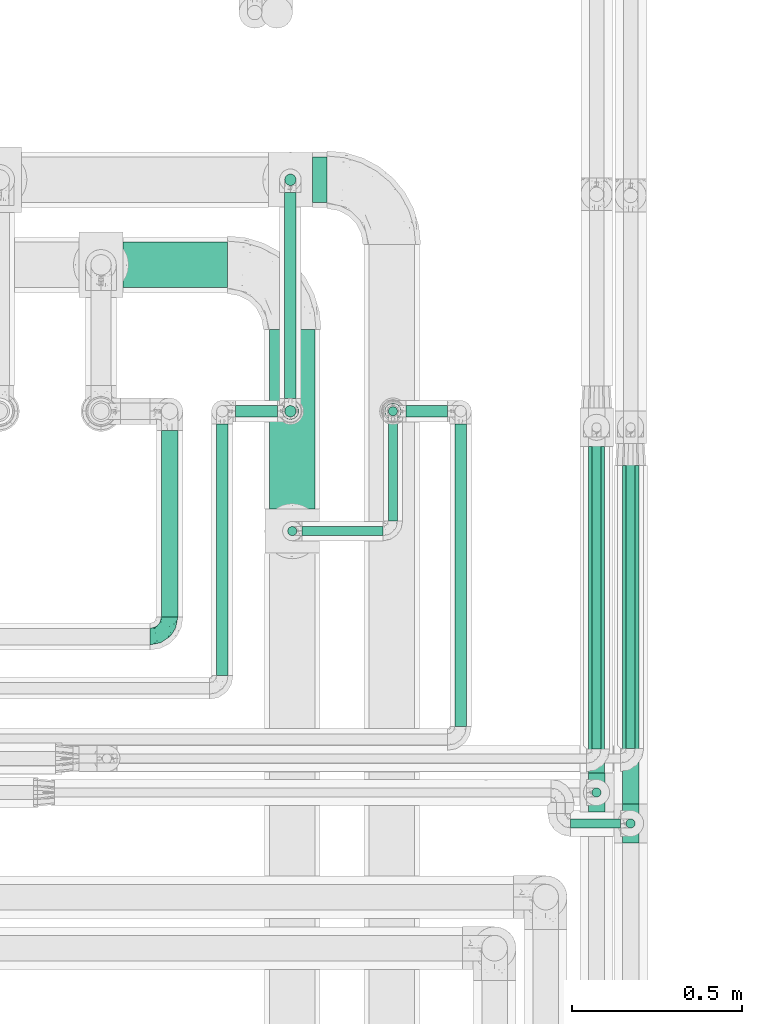
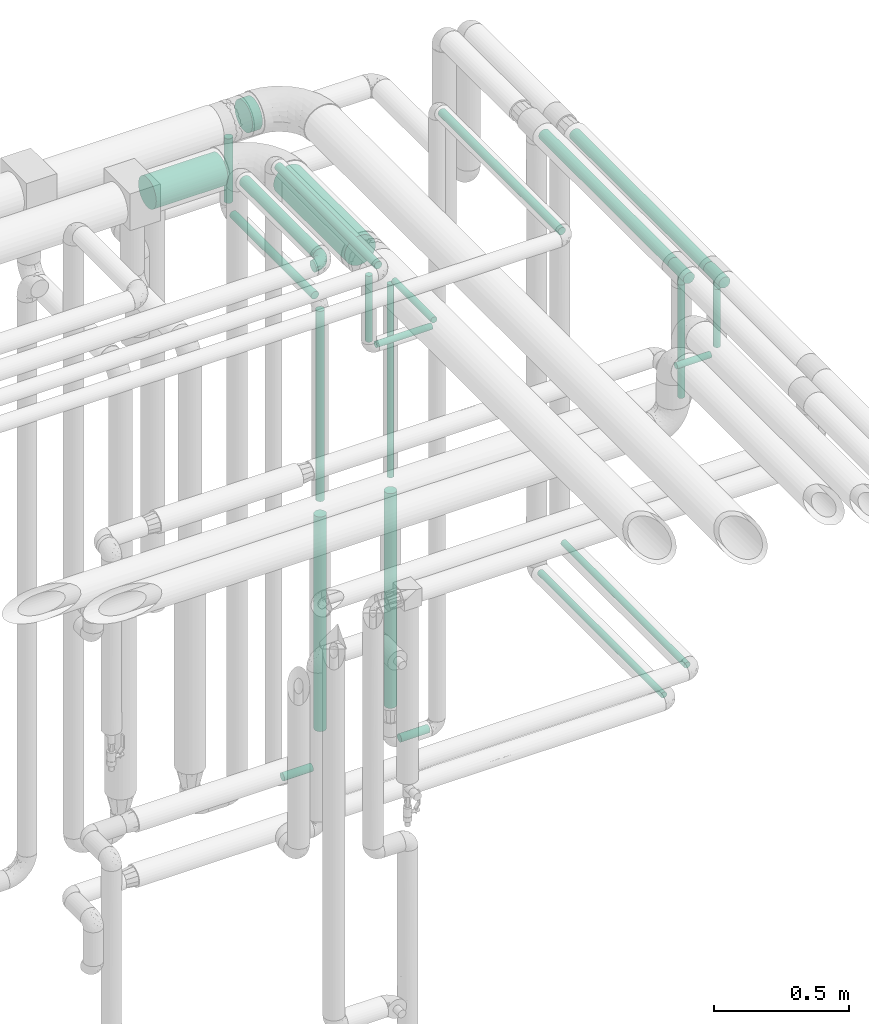
# One storey, part 725 of 827: 24 flow segments, 3 flow fittings.
"""IFC2X3 building model written with IfcOpenShell, lengths in millimetres."""

from ifc_helpers import new_model, entity, si_unit, converted_unit, derived_unit, direction, frame, origin, origin_2d_with_axis, place, context, subcontext, project, spatial, circle, extrude, faceted_brep, source, transform, mapped, material, type_object, type_shapes, element, save


model = new_model("IFC2X3")

# Units and contexts
model_context = context("Model", 3, precision=0.01, world=origin(), true_north=direction((6.12303176911189e-17, 1.0)))
body_context = subcontext(model_context, "Body", "Model", "MODEL_VIEW")
ifc_project = project(units=[si_unit("LENGTHUNIT", "METRE", prefix="MILLI"), si_unit("AREAUNIT", "SQUARE_METRE"), si_unit("VOLUMEUNIT", "CUBIC_METRE"), converted_unit("PLANEANGLEUNIT", "DEGREE", entity("IfcRatioMeasure", 0.0174532925199433), si_unit("PLANEANGLEUNIT", "RADIAN"), dimensions=[0, 0, 0, 0, 0, 0, 0]), si_unit("MASSUNIT", "GRAM", prefix="KILO"), derived_unit("MASSDENSITYUNIT", [(si_unit("MASSUNIT", "GRAM", prefix="KILO"), 1), (si_unit("LENGTHUNIT", "METRE"), -3)]), derived_unit("MOMENTOFINERTIAUNIT", [(si_unit("LENGTHUNIT", "METRE"), 4)]), si_unit("TIMEUNIT", "SECOND"), si_unit("FREQUENCYUNIT", "HERTZ"), si_unit("THERMODYNAMICTEMPERATUREUNIT", "DEGREE_CELSIUS"), derived_unit("THERMALTRANSMITTANCEUNIT", [(si_unit("MASSUNIT", "GRAM", prefix="KILO"), 1), (si_unit("THERMODYNAMICTEMPERATUREUNIT", "KELVIN"), -1), (si_unit("TIMEUNIT", "SECOND"), -3)]), derived_unit("VOLUMETRICFLOWRATEUNIT", [(si_unit("LENGTHUNIT", "METRE"), 3), (si_unit("TIMEUNIT", "SECOND"), -1)]), derived_unit("MASSFLOWRATEUNIT", [(si_unit("MASSUNIT", "GRAM", prefix="KILO"), 1), (si_unit("TIMEUNIT", "SECOND"), -1)]), derived_unit("ROTATIONALFREQUENCYUNIT", [(si_unit("TIMEUNIT", "SECOND"), -1)]), si_unit("ELECTRICCURRENTUNIT", "AMPERE"), si_unit("ELECTRICVOLTAGEUNIT", "VOLT"), si_unit("POWERUNIT", "WATT"), si_unit("FORCEUNIT", "NEWTON", prefix="KILO"), si_unit("ILLUMINANCEUNIT", "LUX"), si_unit("LUMINOUSFLUXUNIT", "LUMEN"), si_unit("LUMINOUSINTENSITYUNIT", "CANDELA"), derived_unit("USERDEFINED", [(si_unit("MASSUNIT", "GRAM", prefix="KILO"), -1), (si_unit("LENGTHUNIT", "METRE"), -2), (si_unit("TIMEUNIT", "SECOND"), 3), (si_unit("LUMINOUSFLUXUNIT", "LUMEN"), 1)]), derived_unit("LINEARVELOCITYUNIT", [(si_unit("LENGTHUNIT", "METRE"), 1), (si_unit("TIMEUNIT", "SECOND"), -1)]), si_unit("PRESSUREUNIT", "PASCAL"), derived_unit("USERDEFINED", [(si_unit("LENGTHUNIT", "METRE"), -2), (si_unit("MASSUNIT", "GRAM", prefix="KILO"), 1), (si_unit("TIMEUNIT", "SECOND"), -2)]), derived_unit("LINEARFORCEUNIT", [(si_unit("MASSUNIT", "GRAM", prefix="KILO"), 1), (si_unit("LENGTHUNIT", "METRE"), 1), (si_unit("TIMEUNIT", "SECOND"), -2), (si_unit("LENGTHUNIT", "METRE"), -1)]), derived_unit("PLANARFORCEUNIT", [(si_unit("MASSUNIT", "GRAM", prefix="KILO"), 1), (si_unit("LENGTHUNIT", "METRE"), 1), (si_unit("TIMEUNIT", "SECOND"), -2), (si_unit("LENGTHUNIT", "METRE"), -2)])], contexts=[model_context])

# Site, building, storey
site_placement = place(None, origin())
site = spatial("IfcSite", under=ifc_project, at=site_placement, CompositionType="ELEMENT")
building_placement = place(site_placement, origin())
building = spatial("IfcBuilding", under=site, at=building_placement, CompositionType="ELEMENT")
storey_placement = place(building_placement, frame((0.0, 0.0, 28200.0)))
storey = spatial("IfcBuildingStorey", under=building, at=storey_placement, Name="08", CompositionType="ELEMENT", Elevation=28200.0)

# Flow segments
pipe_segment_type_1 = type_object("IfcPipeSegmentType", PredefinedType="NOTDEFINED")
flow_segment_1_placement = place(storey_placement, frame((60218.13, 18112.0, 2831.9)))
element("IfcFlowSegment", 1, at=flow_segment_1_placement, inside=storey, type_object=pipe_segment_type_1, context=body_context, shape_type="SweptSolid", body=[
    extrude(circle(Radius=66.5, at=origin_2d_with_axis()), frame((0.0, 68.1, 68.1), z_axis=(1.0, 0.0, 0.0), x_axis=(0.0, 1.0, 0.0)), (0.0, 0.0, 1.0), 42.9168860607221),
])
flow_segment_2_placement = place(storey_placement, frame((59661.67, 17862.0, 2831.87)))
element("IfcFlowSegment", 2, at=flow_segment_2_placement, inside=storey, type_object=pipe_segment_type_1, context=body_context, shape_type="SweptSolid", body=[
    extrude(circle(Radius=66.5, at=origin_2d_with_axis()), frame((0.0, 68.1, 68.1), z_axis=(1.0, 0.0, 0.0), x_axis=(0.0, 1.0, 0.0)), (0.0, 0.0, 1.0), 306.875508273996),
])
flow_segment_3_placement = place(storey_placement, frame((60090.45, 17212.79, 2831.87)))
element("IfcFlowSegment", 3, at=flow_segment_3_placement, inside=storey, type_object=pipe_segment_type_1, context=body_context, shape_type="SweptSolid", body=[
    extrude(circle(Radius=66.5, at=origin_2d_with_axis()), frame((68.1, 0.0, 68.1), z_axis=(0.0, 1.0, 0.0), x_axis=(-1.0, 0.0, 0.0)), (0.0, 0.0, 1.0), 527.308325226667),
])
pipe_segment_type_2 = type_object("IfcPipeSegmentType", PredefinedType="NOTDEFINED")
flow_segment_4_placement = place(storey_placement, frame((61137.64, 16508.75, 1085.0)))
element("IfcFlowSegment", 4, at=flow_segment_4_placement, inside=storey, type_object=pipe_segment_type_2, context=body_context, shape_type="SweptSolid", body=[
    extrude(circle(Radius=13.4, at=origin_2d_with_axis()), frame((15.0, 0.0, 15.0), z_axis=(0.0, 1.0, 0.0), x_axis=(-1.0, 0.0, 0.0)), (0.0, 0.0, 1.0), 914.980860831878),
])
flow_segment_5_placement = place(storey_placement, frame((61137.64, 16273.88, 2679.1)))
element("IfcFlowSegment", 5, at=flow_segment_5_placement, inside=storey, type_object=pipe_segment_type_2, context=body_context, shape_type="SweptSolid", body=[
    extrude(circle(Radius=13.4, at=origin_2d_with_axis()), frame((15.0, 15.0, 0.0)), (0.0, 0.0, 1.0), 263.643188805698),
])
flow_segment_6_placement = place(storey_placement, frame((61127.04, 16345.88, 2974.15)))
element("IfcFlowSegment", 6, at=flow_segment_6_placement, inside=storey, type_object=pipe_segment_type_2, context=body_context, shape_type="SweptSolid", body=[
    extrude(circle(Radius=24.0, at=origin_2d_with_axis()), frame((25.6, 0.0, 25.6), z_axis=(0.0, 1.0, 0.0), x_axis=(-1.0, 0.0, 0.0)), (0.0, 0.0, 1.0), 994.955864647867),
])
flow_segment_7_placement = place(storey_placement, frame((61037.64, 16364.84, 2429.1)))
element("IfcFlowSegment", 7, at=flow_segment_7_placement, inside=storey, type_object=pipe_segment_type_2, context=body_context, shape_type="SweptSolid", body=[
    extrude(circle(Radius=13.4, at=origin_2d_with_axis()), frame((15.0, 15.0, 0.0)), (0.0, 0.0, 1.0), 513.643188805697),
])
flow_segment_8_placement = place(storey_placement, frame((61027.04, 16436.84, 2974.15)))
element("IfcFlowSegment", 8, at=flow_segment_8_placement, inside=storey, type_object=pipe_segment_type_2, context=body_context, shape_type="SweptSolid", body=[
    extrude(circle(Radius=24.0, at=origin_2d_with_axis()), frame((25.6, 0.0, 25.6), z_axis=(0.0, 1.0, 0.0), x_axis=(-1.0, 0.0, 0.0)), (0.0, 0.0, 1.0), 958.995662655606),
])
flow_segment_9_placement = place(storey_placement, frame((61037.64, 16508.26, 985.01)))
element("IfcFlowSegment", 9, at=flow_segment_9_placement, inside=storey, type_object=pipe_segment_type_2, context=body_context, shape_type="SweptSolid", body=[
    extrude(circle(Radius=13.4, at=origin_2d_with_axis()), frame((15.0, 0.0, 15.0), z_axis=(0.0, 1.0, 0.0), x_axis=(1.0, 0.0, 0.0)), (0.0, 0.0, 1.0), 915.473302419628),
])
flow_segment_10_placement = place(storey_placement, frame((60134.79, 17538.0, 2481.65)))
element("IfcFlowSegment", 10, at=flow_segment_10_placement, inside=storey, type_object=pipe_segment_type_2, context=body_context, shape_type="SweptSolid", body=[
    extrude(circle(Radius=16.75, at=origin_2d_with_axis()), frame((18.35, 0.0, 18.35), z_axis=(0.0, 1.0, 0.0), x_axis=(-1.0, 0.0, 0.0)), (0.0, 0.0, 1.0), 604.096114108988),
])
flow_segment_11_placement = place(storey_placement, frame((60134.79, 18161.75, 2538.0)))
element("IfcFlowSegment", 11, at=flow_segment_11_placement, inside=storey, type_object=pipe_segment_type_2, context=body_context, shape_type="SweptSolid", body=[
    extrude(circle(Radius=16.75, at=origin_2d_with_axis()), frame((18.35, 18.35, 0.0), z_axis=(0.0, 0.0, 1.0), x_axis=(-1.0, 0.0, 0.0)), (0.0, 0.0, 1.0), 291.999999999986),
])
flow_segment_12_placement = place(storey_placement, frame((60134.79, 17481.65, 1600.0)))
element("IfcFlowSegment", 12, at=flow_segment_12_placement, inside=storey, type_object=pipe_segment_type_2, context=body_context, shape_type="SweptSolid", body=[
    extrude(circle(Radius=16.75, at=origin_2d_with_axis()), frame((18.35, 18.35, 0.0)), (0.0, 0.0, 1.0), 862.000000000012),
])
flow_segment_13_placement = place(storey_placement, frame((60143.55, 17132.79, 2531.09)))
element("IfcFlowSegment", 13, at=flow_segment_13_placement, inside=storey, type_object=pipe_segment_type_2, context=body_context, shape_type="SweptSolid", body=[
    extrude(circle(Radius=13.4, at=origin_2d_with_axis()), frame((15.0, 15.0, 0.0)), (0.0, 0.0, 1.0), 298.905011104185),
])
flow_segment_14_placement = place(storey_placement, frame((60187.65, 17132.79, 2487.0)))
element("IfcFlowSegment", 14, at=flow_segment_14_placement, inside=storey, type_object=pipe_segment_type_2, context=body_context, shape_type="SweptSolid", body=[
    extrude(circle(Radius=13.4, at=origin_2d_with_axis()), frame((0.0, 15.0, 15.0), z_axis=(1.0, 0.0, 0.0), x_axis=(0.0, -1.0, 0.0)), (0.0, 0.0, 1.0), 237.633062103833),
])
flow_segment_15_placement = place(storey_placement, frame((60439.39, 17176.89, 2487.0)))
element("IfcFlowSegment", 15, at=flow_segment_15_placement, inside=storey, type_object=pipe_segment_type_2, context=body_context, shape_type="SweptSolid", body=[
    extrude(circle(Radius=13.4, at=origin_2d_with_axis()), frame((15.0, 0.0, 15.0), z_axis=(0.0, 1.0, 0.0), x_axis=(1.0, 0.0, 0.0)), (0.0, 0.0, 1.0), 294.012227432359),
])
flow_segment_16_placement = place(storey_placement, frame((60439.39, 17485.0, 1600.0)))
element("IfcFlowSegment", 16, at=flow_segment_16_placement, inside=storey, type_object=pipe_segment_type_2, context=body_context, shape_type="SweptSolid", body=[
    extrude(circle(Radius=13.4, at=origin_2d_with_axis()), frame((15.0, 15.0, 0.0)), (0.0, 0.0, 1.0), 872.894988927772),
])
flow_segment_17_placement = place(storey_placement, frame((60492.38, 17481.65, 381.65)))
element("IfcFlowSegment", 17, at=flow_segment_17_placement, inside=storey, type_object=pipe_segment_type_2, context=body_context, shape_type="SweptSolid", body=[
    extrude(circle(Radius=16.75, at=origin_2d_with_axis()), frame((0.0, 18.35, 18.35), z_axis=(1.0, 0.0, 0.0), x_axis=(0.0, 1.0, 0.0)), (0.0, 0.0, 1.0), 122.750000000028),
])
flow_segment_18_placement = place(storey_placement, frame((59991.13, 17481.65, 381.65)))
element("IfcFlowSegment", 18, at=flow_segment_18_placement, inside=storey, type_object=pipe_segment_type_2, context=body_context, shape_type="SweptSolid", body=[
    extrude(circle(Radius=16.75, at=origin_2d_with_axis()), frame((0.0, 18.35, 18.35), z_axis=(1.0, 0.0, 0.0), x_axis=(0.0, -1.0, 0.0)), (0.0, 0.0, 1.0), 124.000000000015),
])
flow_segment_19_placement = place(storey_placement, frame((59772.54, 16894.94, 3174.4)))
element("IfcFlowSegment", 19, at=flow_segment_19_placement, inside=storey, type_object=pipe_segment_type_2, context=body_context, shape_type="SweptSolid", body=[
    extrude(circle(Radius=24.0, at=origin_2d_with_axis()), frame((25.6, 0.0, 25.6), z_axis=(0.0, 1.0, 0.0), x_axis=(-1.0, 0.0, 0.0)), (0.0, 0.0, 1.0), 548.064099051886),
])
flow_segment_20_placement = place(storey_placement, frame((59934.79, 16723.69, 3181.65)))
element("IfcFlowSegment", 20, at=flow_segment_20_placement, inside=storey, type_object=pipe_segment_type_2, context=body_context, shape_type="SweptSolid", body=[
    extrude(circle(Radius=16.75, at=origin_2d_with_axis()), frame((18.35, 0.0, 18.35), z_axis=(0.0, 1.0, 0.0), x_axis=(-1.0, 0.0, 0.0)), (0.0, 0.0, 1.0), 738.30468635603),
])
flow_segment_21_placement = place(storey_placement, frame((60634.79, 16573.69, 3181.65)))
element("IfcFlowSegment", 21, at=flow_segment_21_placement, inside=storey, type_object=pipe_segment_type_2, context=body_context, shape_type="SweptSolid", body=[
    extrude(circle(Radius=16.75, at=origin_2d_with_axis()), frame((18.35, 0.0, 18.35), z_axis=(0.0, 1.0, 0.0), x_axis=(-1.0, 0.0, 0.0)), (0.0, 0.0, 1.0), 888.304686356007),
])
flow_segment_22_placement = place(storey_placement, frame((60127.54, 17474.4, 564.0)))
element("IfcFlowSegment", 22, at=flow_segment_22_placement, inside=storey, type_object=pipe_segment_type_2, context=body_context, shape_type="SweptSolid", body=[
    extrude(circle(Radius=24.0, at=origin_2d_with_axis()), frame((25.6, 25.6, 0.0)), (0.0, 0.0, 1.0), 971.999999999991),
])
flow_segment_23_placement = place(storey_placement, frame((60428.79, 17474.4, 564.0)))
element("IfcFlowSegment", 23, at=flow_segment_23_placement, inside=storey, type_object=pipe_segment_type_2, context=body_context, shape_type="SweptSolid", body=[
    extrude(circle(Radius=24.0, at=origin_2d_with_axis()), frame((25.6, 25.6, 0.0), z_axis=(0.0, 0.0, 1.0), x_axis=(-1.0, 0.0, 0.0)), (0.0, 0.0, 1.0), 971.999999999987),
])
flow_segment_24_placement = place(storey_placement, frame((60976.74, 16273.88, 2635.0)))
element("IfcFlowSegment", 24, at=flow_segment_24_placement, inside=storey, type_object=pipe_segment_type_2, context=body_context, shape_type="SweptSolid", body=[
    extrude(circle(Radius=13.4, at=origin_2d_with_axis()), frame((0.0, 15.0, 15.0), z_axis=(1.0, 0.0, 0.0), x_axis=(0.0, 1.0, 0.0)), (0.0, 0.0, 1.0), 146.800000000001),
])

# Flow fittings
ifc_material = material()
pipe_fitting_type_1 = type_object("IfcPipeFittingType", Name="ADSK_1", PredefinedType="NOTDEFINED", material=ifc_material)
shared_shape_1 = source(origin(), body_context, "Body", "Brep", [
    faceted_brep([(-57.0, 12.07, -20.91), (-57.0, 6.25, -23.33), (-57.0, 0.0, -24.15), (-57.0, -6.25, -23.33), (-57.0, -12.08, -20.91), (-57.0, -17.08, -17.08), (-57.0, -20.91, -12.08), (-57.0, -23.33, -6.25), (-57.0, -24.15, 0.0), (-57.0, -23.33, 6.25), (-57.0, -20.91, 12.07), (-57.0, -17.08, 17.08), (-57.0, -12.08, 20.91), (-57.0, -6.25, 23.33), (-57.0, 0.0, 24.15), (-57.0, 6.25, 23.33), (-57.0, 12.07, 20.91), (-57.0, 17.08, 17.08), (-57.0, 20.91, 12.07), (-57.0, 23.33, 6.25), (-57.0, 24.15, 0.0), (-57.0, 23.33, -6.25), (-57.0, 20.91, -12.08), (-57.0, 17.08, -17.08), (0.0, 57.0, -24.15), (-6.25, 57.0, -23.33), (-12.07, 57.0, -20.91), (-17.08, 57.0, -17.08), (-20.91, 57.0, -12.08), (-23.33, 57.0, -6.25), (-24.15, 57.0, 0.0), (-23.33, 57.0, 6.25), (-20.91, 57.0, 12.07), (-17.08, 57.0, 17.08), (-12.07, 57.0, 20.91), (-6.25, 57.0, 23.33), (0.0, 57.0, 24.15), (6.25, 57.0, 23.33), (12.08, 57.0, 20.91), (17.08, 57.0, 17.08), (20.91, 57.0, 12.07), (23.33, 57.0, 6.25), (24.15, 57.0, 0.0), (23.33, 57.0, -6.25), (20.91, 57.0, -12.08), (17.08, 57.0, -17.08), (12.08, 57.0, -20.91), (6.25, 57.0, -23.33), (14.9, 21.14, 6.17), (13.61, 24.64, 12.48), (6.23, 8.95, 8.98), (-41.47, -21.06, 0.0), (-41.92, -18.38, 13.72), (-24.64, -13.61, 12.48), (-37.37, -13.24, 18.15), (-6.8, -4.93, 8.18), (-21.76, -15.19, 6.22), (-12.78, -9.18, 0.0), (-37.73, -20.51, 7.75), (-7.38, 7.38, 20.24), (-23.37, -4.26, 20.42), (-11.9, -3.19, 15.86), (-42.14, -8.7, 21.82), (13.24, 37.37, 18.15), (9.33, 23.53, 16.85), (4.26, 23.37, 20.42), (2.77, 10.92, 15.55), (-29.46, 0.91, 23.52), (-44.13, 20.56, 15.69), (-39.25, 26.33, 10.88), (-49.02, 22.92, 9.96), (-34.58, 23.87, 17.15), (-15.8, 6.8, 22.81), (-8.67, 20.47, 23.88), (-18.12, 12.9, 24.08), (-48.29, 14.92, 19.65), (-44.06, -2.85, 23.78), (-9.23, 48.95, 22.58), (-3.78, 42.74, 24.07), (-40.34, 4.26, 24.09), (-44.02, 26.14, 5.46), (-44.04, 9.88, 22.74), (-4.95, 16.87, 22.52), (-2.75, 1.43, 12.5), (-25.48, 40.98, 10.71), (20.51, 37.73, 7.75), (18.38, 41.92, 13.72), (8.7, 42.14, 21.82), (-25.95, -17.97, 0.0), (2.85, 44.06, 23.78), (21.06, 41.47, 0.0), (17.97, 25.95, 0.0), (-24.04, -9.27, 17.13), (-33.26, 33.26, 5.86), (-28.55, 40.57, 0.0), (-40.57, 28.55, 0.0), (-25.29, 47.19, 4.06), (-27.01, 31.1, 16.77), (-15.7, 43.95, 19.9), (-20.27, 45.22, 15.61), (-30.53, 31.98, 12.64), (-11.28, 38.33, 22.92), (-9.97, 27.88, 24.09), (-20.15, 30.26, 21.25), (-31.25, 11.75, 23.64), (-28.75, 7.23, 24.15), (-29.53, 18.06, 22.27), (-28.44, 24.21, 20.02), (-37.55, 17.7, 20.26), (-15.88, 29.25, 22.99), (-20.82, 20.82, 23.44), (-0.91, 29.46, 23.52), (-13.5, -7.67, 12.04), (1.49, 1.56, 5.16), (8.86, 10.35, 4.59), (0.38, -0.38, 0.0), (9.18, 12.78, 0.0), (-37.37, -13.24, -18.15), (8.86, 10.35, -4.59), (-45.22, 20.27, -15.61), (-43.95, 15.7, -19.9), (-38.33, 11.28, -22.92), (-48.95, 9.23, -22.58), (-47.19, 25.29, -4.06), (-33.26, 33.26, -5.86), (18.38, 41.92, -13.72), (-30.26, 20.15, -21.25), (2.85, 44.06, -23.78), (-4.26, 40.34, -24.09), (-40.98, 25.48, -10.71), (-41.92, -18.38, -13.72), (9.25, 23.5, -16.92), (4.26, 23.37, -20.42), (13.24, 37.37, -18.15), (-37.73, -20.51, -7.75), (-11.75, 31.25, -23.64), (-7.23, 28.75, -24.15), (-12.9, 18.12, -24.08), (8.7, 42.14, -21.82), (-44.06, -2.85, -23.78), (-6.8, 15.8, -22.81), (-20.47, 8.67, -23.88), (-24.64, -13.61, -12.48), (-42.74, 3.78, -24.07), (-18.06, 29.53, -22.27), (-24.21, 28.44, -20.02), (-27.88, 9.97, -24.09), (-31.1, 27.01, -16.77), (-26.14, 44.02, -5.46), (14.9, 21.14, -6.17), (20.51, 37.73, -7.75), (-9.88, 44.04, -22.74), (-20.56, 44.13, -15.69), (-21.76, -15.19, -6.22), (-13.5, -7.67, -12.04), (-24.14, -9.76, -16.74), (-11.9, -3.19, -15.86), (-14.92, 48.29, -19.65), (-23.37, -4.26, -20.42), (-0.91, 29.46, -23.52), (-26.33, 39.25, -10.88), (-23.87, 34.58, -17.15), (-42.14, -8.7, -21.82), (-22.92, 49.02, -9.96), (13.61, 24.64, -12.48), (-31.98, 30.53, -12.64), (-16.87, 4.95, -22.52), (-17.7, 37.55, -20.26), (-29.25, 15.88, -22.99), (-20.82, 20.82, -23.44), (-29.46, 0.91, -23.52), (-7.38, 7.38, -20.24), (2.77, 10.92, -15.55), (6.23, 8.95, -8.98), (-6.8, -4.93, -8.18), (-2.81, 1.41, -12.54), (1.49, 1.56, -5.16)], [[[0, 1, 2, 3, 4, 5, 6, 7, 8, 9, 10, 11, 12, 13, 14, 15, 16, 17, 18, 19, 20, 21, 22, 23]], [[24, 25, 26, 27, 28, 29, 30, 31, 32, 33, 34, 35, 36, 37, 38, 39, 40, 41, 42, 43, 44, 45, 46, 47]], [[48, 49, 50]], [[9, 8, 51]], [[52, 53, 54]], [[55, 56, 57]], [[10, 58, 52]], [[9, 58, 10]], [[59, 60, 61]], [[54, 12, 11]], [[54, 62, 12]], [[63, 39, 38]], [[64, 65, 66]], [[62, 60, 67]], [[68, 69, 70]], [[71, 69, 68]], [[72, 73, 74]], [[16, 75, 17]], [[13, 76, 14]], [[35, 77, 78]], [[14, 79, 15]], [[17, 68, 18]], [[14, 76, 79]], [[20, 19, 80]], [[70, 19, 18]], [[81, 15, 79]], [[15, 81, 16]], [[73, 72, 82]], [[66, 83, 50]], [[32, 31, 84]], [[85, 86, 49]], [[63, 87, 65]], [[56, 58, 88]], [[36, 89, 37]], [[85, 41, 40]], [[36, 35, 78]], [[90, 41, 85]], [[40, 39, 86]], [[12, 62, 13]], [[86, 85, 40]], [[48, 85, 49]], [[85, 91, 90]], [[87, 38, 37]], [[92, 60, 54]], [[80, 69, 93]], [[93, 94, 95]], [[10, 52, 11]], [[94, 96, 30]], [[97, 98, 99]], [[80, 93, 95]], [[100, 97, 84]], [[99, 98, 33]], [[101, 102, 78]], [[103, 101, 98]], [[96, 31, 30]], [[77, 98, 101]], [[77, 35, 34]], [[34, 33, 98]], [[9, 51, 58]], [[87, 63, 38]], [[104, 105, 74]], [[106, 103, 107]], [[106, 81, 104]], [[75, 68, 17]], [[108, 107, 71]], [[33, 32, 99]], [[109, 103, 110]], [[101, 109, 102]], [[89, 78, 111]], [[53, 52, 58]], [[54, 11, 52]], [[60, 62, 54]], [[88, 58, 51]], [[76, 62, 67]], [[53, 112, 92]], [[60, 59, 72]], [[39, 63, 86]], [[49, 86, 63]], [[89, 87, 37]], [[42, 41, 90]], [[111, 82, 65]], [[111, 65, 87]], [[65, 59, 66]], [[104, 81, 79]], [[75, 81, 108]], [[32, 84, 99]], [[97, 99, 84]], [[98, 97, 103]], [[106, 107, 108]], [[74, 102, 110]], [[111, 78, 102]], [[74, 110, 104]], [[74, 67, 72]], [[61, 92, 112]], [[66, 59, 61]], [[56, 53, 58]], [[66, 50, 49]], [[61, 112, 83]], [[66, 49, 64]], [[78, 89, 36]], [[87, 89, 111]], [[62, 76, 13]], [[79, 76, 67]], [[100, 93, 69]], [[96, 93, 84]], [[55, 113, 50]], [[113, 114, 50]], [[104, 79, 105]], [[106, 104, 110]], [[20, 80, 95]], [[85, 48, 91]], [[115, 114, 113]], [[116, 91, 48]], [[70, 80, 19]], [[93, 96, 94]], [[84, 31, 96]], [[103, 106, 110]], [[81, 106, 108]], [[103, 97, 107]], [[71, 107, 97]], [[71, 97, 100]], [[108, 71, 68]], [[79, 67, 105]], [[67, 74, 105]], [[115, 113, 57]], [[112, 56, 55]], [[56, 88, 57]], [[60, 72, 67]], [[82, 72, 59]], [[65, 82, 59]], [[82, 111, 73]], [[111, 102, 73]], [[102, 74, 73]], [[81, 75, 16]], [[68, 75, 108]], [[68, 70, 18]], [[80, 70, 69]], [[98, 77, 34]], [[78, 77, 101]], [[93, 100, 84]], [[71, 100, 69]], [[102, 109, 110]], [[101, 103, 109]], [[53, 92, 54]], [[61, 60, 92]], [[56, 112, 53]], [[83, 112, 55]], [[50, 83, 55]], [[61, 83, 66]], [[49, 63, 64]], [[65, 64, 63]], [[57, 113, 55]], [[114, 115, 116]], [[116, 48, 114]], [[48, 50, 114]], [[117, 5, 4]], [[116, 115, 118]], [[119, 120, 23]], [[121, 122, 120]], [[95, 123, 20]], [[0, 23, 120]], [[124, 95, 94]], [[125, 45, 44]], [[121, 120, 126]], [[24, 127, 128]], [[22, 21, 129]], [[0, 122, 1]], [[5, 117, 130]], [[131, 132, 133]], [[134, 88, 51]], [[135, 136, 137]], [[6, 5, 130]], [[46, 138, 47]], [[139, 3, 2]], [[140, 141, 137]], [[6, 134, 7]], [[134, 130, 142]], [[143, 2, 1]], [[144, 126, 145]], [[121, 146, 143]], [[147, 120, 119]], [[94, 148, 124]], [[149, 150, 91]], [[30, 29, 148]], [[151, 25, 128]], [[27, 152, 28]], [[134, 153, 88]], [[154, 155, 156]], [[27, 26, 157]], [[151, 26, 25]], [[155, 158, 156]], [[24, 47, 127]], [[1, 122, 143]], [[138, 132, 159]], [[160, 152, 161]], [[24, 128, 25]], [[46, 133, 138]], [[162, 117, 4]], [[148, 160, 124]], [[152, 160, 163]], [[154, 142, 155]], [[45, 125, 133]], [[133, 46, 45]], [[125, 164, 133]], [[51, 7, 134]], [[42, 90, 43]], [[165, 147, 129]], [[153, 134, 142]], [[43, 150, 44]], [[162, 4, 3]], [[141, 140, 166]], [[117, 162, 158]], [[163, 29, 28]], [[43, 90, 150]], [[123, 21, 20]], [[144, 151, 135]], [[157, 152, 27]], [[167, 145, 161]], [[23, 22, 119]], [[168, 126, 169]], [[121, 168, 146]], [[139, 143, 170]], [[142, 130, 117]], [[8, 7, 51]], [[134, 6, 130]], [[139, 162, 3]], [[170, 166, 158]], [[170, 158, 162]], [[158, 171, 156]], [[44, 150, 125]], [[91, 150, 90]], [[164, 125, 150]], [[132, 138, 133]], [[127, 138, 159]], [[131, 164, 172]], [[132, 171, 140]], [[135, 151, 128]], [[157, 151, 167]], [[22, 129, 119]], [[147, 119, 129]], [[120, 147, 126]], [[144, 145, 167]], [[137, 146, 169]], [[170, 143, 146]], [[137, 169, 135]], [[137, 159, 140]], [[171, 172, 156]], [[173, 174, 175]], [[156, 175, 154]], [[174, 57, 153]], [[132, 172, 171]], [[172, 164, 173]], [[143, 139, 2]], [[162, 139, 170]], [[138, 127, 47]], [[128, 127, 159]], [[165, 124, 160]], [[123, 124, 129]], [[149, 173, 164]], [[176, 174, 173]], [[135, 128, 136]], [[144, 135, 169]], [[150, 149, 164]], [[176, 118, 115]], [[149, 91, 116]], [[30, 148, 94]], [[163, 148, 29]], [[124, 123, 95]], [[129, 21, 123]], [[126, 144, 169]], [[151, 144, 167]], [[126, 147, 145]], [[161, 145, 147]], [[161, 147, 165]], [[167, 161, 152]], [[128, 159, 136]], [[159, 137, 136]], [[154, 153, 142]], [[132, 140, 159]], [[174, 176, 57]], [[57, 88, 153]], [[166, 140, 171]], [[158, 166, 171]], [[166, 170, 141]], [[170, 146, 141]], [[146, 137, 141]], [[151, 157, 26]], [[152, 157, 167]], [[152, 163, 28]], [[148, 163, 160]], [[120, 122, 0]], [[143, 122, 121]], [[124, 165, 129]], [[161, 165, 160]], [[146, 168, 169]], [[121, 126, 168]], [[142, 117, 155]], [[158, 155, 117]], [[175, 156, 172]], [[153, 154, 174]], [[173, 175, 172]], [[174, 154, 175]], [[164, 131, 133]], [[172, 132, 131]], [[176, 173, 118]], [[57, 176, 115]], [[173, 149, 118]], [[149, 116, 118]]]),
])
type_shapes(pipe_fitting_type_1, [shared_shape_1])
flow_fitting_placement = place(storey_placement, frame((59798.13, 16837.94, 3200.0)))
element("IfcFlowFitting", 25, at=flow_fitting_placement, inside=storey, type_object=pipe_fitting_type_1, material=ifc_material, Name="ADSK_1", ObjectType="ADSK_1", context=body_context, shape_type="MappedRepresentation", body=[
    mapped(shared_shape_1, transform((0.0, 0.0, 0.0), scale=1.0)),
])
pipe_fitting_type_2 = type_object("IfcPipeFittingType", Name="ADSK_1", PredefinedType="NOTDEFINED", material=ifc_material)
shared_shape_2 = source(origin(), body_context, "Body", "Brep", [
    faceted_brep([(-57.0, 12.07, -20.91), (-57.0, 6.25, -23.33), (-57.0, 0.0, -24.15), (-57.0, -6.25, -23.33), (-57.0, -12.08, -20.91), (-57.0, -17.08, -17.08), (-57.0, -20.91, -12.08), (-57.0, -23.33, -6.25), (-57.0, -24.15, 0.0), (-57.0, -23.33, 6.25), (-57.0, -20.91, 12.07), (-57.0, -17.08, 17.08), (-57.0, -12.08, 20.91), (-57.0, -6.25, 23.33), (-57.0, 0.0, 24.15), (-57.0, 6.25, 23.33), (-57.0, 12.07, 20.91), (-57.0, 17.08, 17.08), (-57.0, 20.91, 12.07), (-57.0, 23.33, 6.25), (-57.0, 24.15, 0.0), (-57.0, 23.33, -6.25), (-57.0, 20.91, -12.08), (-57.0, 17.08, -17.08), (57.0, 0.0, -24.15), (57.0, 6.25, -23.33), (57.0, 12.07, -20.91), (57.0, 17.08, -17.08), (57.0, 20.91, -12.08), (57.0, 23.33, -6.25), (57.0, 24.15, 0.0), (57.0, 23.33, 6.25), (57.0, 20.91, 12.07), (57.0, 17.08, 17.08), (57.0, 12.07, 20.91), (57.0, 6.25, 23.33), (57.0, 0.0, 24.15), (57.0, -6.25, 23.33), (57.0, -12.08, 20.91), (57.0, -17.08, 17.08), (57.0, -20.91, 12.07), (57.0, -23.33, 6.25), (57.0, -24.15, 0.0), (57.0, -23.33, -6.25), (57.0, -20.91, -12.08), (57.0, -17.08, -17.08), (57.0, -12.08, -20.91), (57.0, -6.25, -23.33), (12.61, -23.69, 4.67), (13.03, -23.92, 2.34), (13.45, -24.15, 0.0), (10.28, -22.54, 8.68), (2.38, -20.2, 13.24), (6.77, -21.17, 11.62), (4.58, -20.68, 12.43), (-13.45, -24.15, 0.0), (-13.03, -23.92, 2.34), (-12.61, -23.69, 4.67), (-10.28, -22.54, 8.67), (-6.77, -21.17, 11.62), (-4.58, -20.68, 12.43), (-2.38, -20.2, 13.24), (0.0, -20.2, 13.24), (2.38, -20.2, -13.24), (6.77, -21.17, -11.62), (4.58, -20.68, -12.43), (10.28, -22.54, -8.68), (12.61, -23.69, -4.67), (13.03, -23.92, -2.34), (-2.38, -20.2, -13.24), (-4.58, -20.68, -12.43), (-6.77, -21.17, -11.62), (-10.28, -22.54, -8.67), (0.0, -20.2, -13.24), (-12.61, -23.69, -4.67), (-13.03, -23.92, -2.34), (-12.99, -57.0, -3.48), (-11.65, -57.0, -6.73), (-9.51, -57.0, -9.51), (-6.72, -57.0, -11.65), (-3.48, -57.0, -12.99), (0.0, -57.0, -13.45), (3.48, -57.0, -12.99), (6.73, -57.0, -11.65), (9.51, -57.0, -9.51), (11.65, -57.0, -6.73), (12.99, -57.0, -3.48), (13.45, -57.0, 0.0), (12.99, -57.0, 3.48), (11.65, -57.0, 6.72), (9.51, -57.0, 9.51), (6.73, -57.0, 11.65), (3.48, -57.0, 12.99), (0.0, -57.0, 13.45), (-3.48, -57.0, 12.99), (-6.72, -57.0, 11.65), (-9.51, -57.0, 9.51), (-11.65, -57.0, 6.72), (-12.99, -57.0, 3.48), (-13.45, -57.0, 0.0)], [[[0, 1, 2, 3, 4, 5, 6, 7, 8, 9, 10, 11, 12, 13, 14, 15, 16, 17, 18, 19, 20, 21, 22, 23]], [[24, 25, 26, 27, 28, 29, 30, 31, 32, 33, 34, 35, 36, 37, 38, 39, 40, 41, 42, 43, 44, 45, 46, 47]], [[42, 41, 48]], [[42, 48, 49, 50]], [[41, 51, 48]], [[40, 39, 52]], [[53, 51, 40]], [[40, 52, 54, 53]], [[39, 11, 52]], [[40, 51, 41]], [[8, 55, 56, 57]], [[9, 8, 57]], [[57, 58, 9]], [[10, 59, 60, 61]], [[59, 10, 58]], [[10, 61, 11]], [[58, 10, 9]], [[11, 61, 62, 52]], [[39, 38, 12, 11]], [[14, 13, 37, 36]], [[13, 12, 38, 37]], [[15, 14, 36, 35]], [[32, 31, 19, 18]], [[17, 16, 34, 33]], [[18, 17, 33, 32]], [[35, 34, 16, 15]], [[20, 19, 31, 30]], [[29, 28, 22, 21]], [[28, 27, 23, 22]], [[30, 29, 21, 20]], [[24, 47, 3, 2]], [[1, 0, 26, 25]], [[2, 1, 25, 24]], [[27, 26, 0, 23]], [[4, 3, 47, 46]], [[46, 45, 5, 4]], [[45, 44, 63]], [[44, 64, 65, 63]], [[44, 66, 64]], [[45, 63, 5]], [[43, 42, 67]], [[67, 66, 43]], [[42, 50, 68, 67]], [[43, 66, 44]], [[6, 69, 70, 71]], [[6, 5, 69]], [[71, 72, 6]], [[5, 63, 73, 69]], [[72, 74, 7]], [[74, 8, 7]], [[8, 74, 75, 55]], [[72, 7, 6]], [[76, 77, 78, 79, 80, 81, 82, 83, 84, 85, 86, 87, 88, 89, 90, 91, 92, 93, 94, 95, 96, 97, 98, 99]], [[57, 98, 97]], [[59, 96, 95]], [[97, 96, 58]], [[91, 54, 92]], [[56, 99, 98]], [[55, 99, 56]], [[98, 57, 56]], [[58, 57, 97]], [[96, 59, 58]], [[49, 48, 88]], [[60, 59, 95]], [[94, 61, 60]], [[49, 87, 50]], [[93, 52, 62, 61]], [[91, 53, 54]], [[90, 53, 91]], [[48, 89, 88]], [[90, 89, 51]], [[52, 93, 92]], [[54, 52, 92]], [[60, 95, 94]], [[53, 90, 51]], [[51, 89, 48]], [[93, 61, 94]], [[87, 49, 88]], [[86, 68, 87]], [[81, 63, 82]], [[65, 83, 82]], [[65, 64, 83]], [[86, 67, 68]], [[67, 86, 85]], [[75, 74, 76]], [[66, 85, 84]], [[68, 50, 87]], [[67, 85, 66]], [[79, 70, 80]], [[64, 66, 84]], [[82, 63, 65]], [[64, 84, 83]], [[81, 69, 73, 63]], [[79, 71, 70]], [[78, 71, 79]], [[74, 77, 76]], [[78, 77, 72]], [[69, 81, 80]], [[70, 69, 80]], [[71, 78, 72]], [[72, 77, 74]], [[99, 75, 76]], [[75, 99, 55]]]),
])
type_shapes(pipe_fitting_type_2, [shared_shape_2])
for number, where, z_axis, x_axis, name in (
    (26, (61152.64, 16288.88, 2999.74), (1.0, 0.0, 0.0), (0.0, 1.0, 0.0), "ADSK_1"),
    (27, (61052.64, 16379.84, 2999.74), (1.0, 0.0, 0.0), (0.0, 1.0, 0.0), "ADSK_1"),
):
    element("IfcFlowFitting", number, at=place(storey_placement, frame(where, z_axis=z_axis, x_axis=x_axis)), inside=storey, type_object=pipe_fitting_type_2, material=ifc_material, Name=name, ObjectType="ADSK_1", context=body_context, shape_type="MappedRepresentation", body=[
        mapped(shared_shape_2, transform((0.0, 0.0, 0.0), scale=1.0)),
    ])

save(model, "model.ifc")
